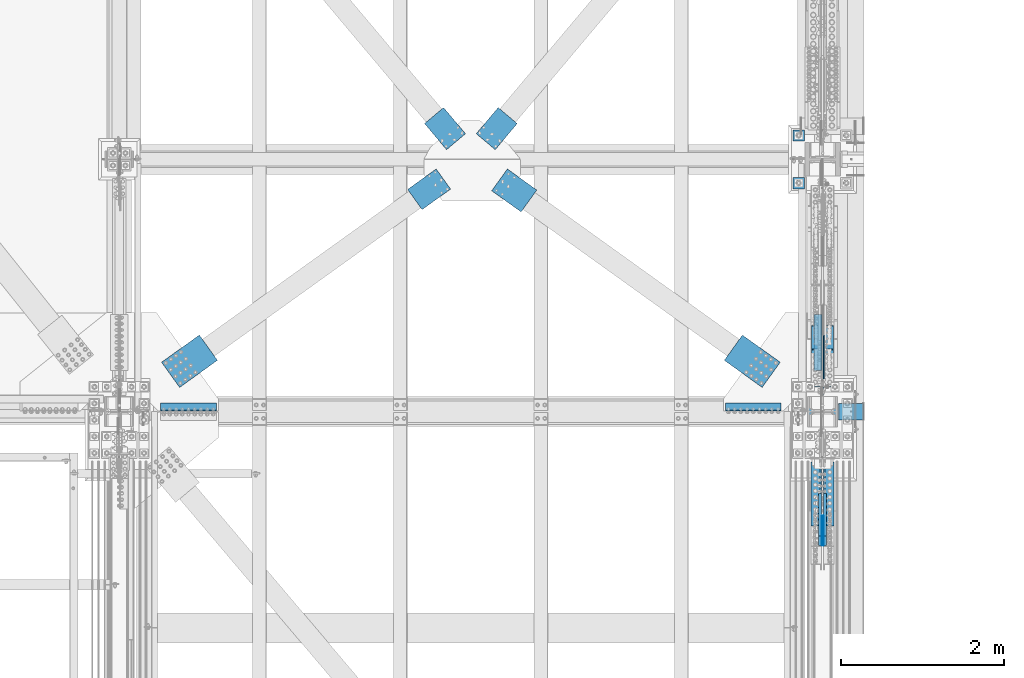
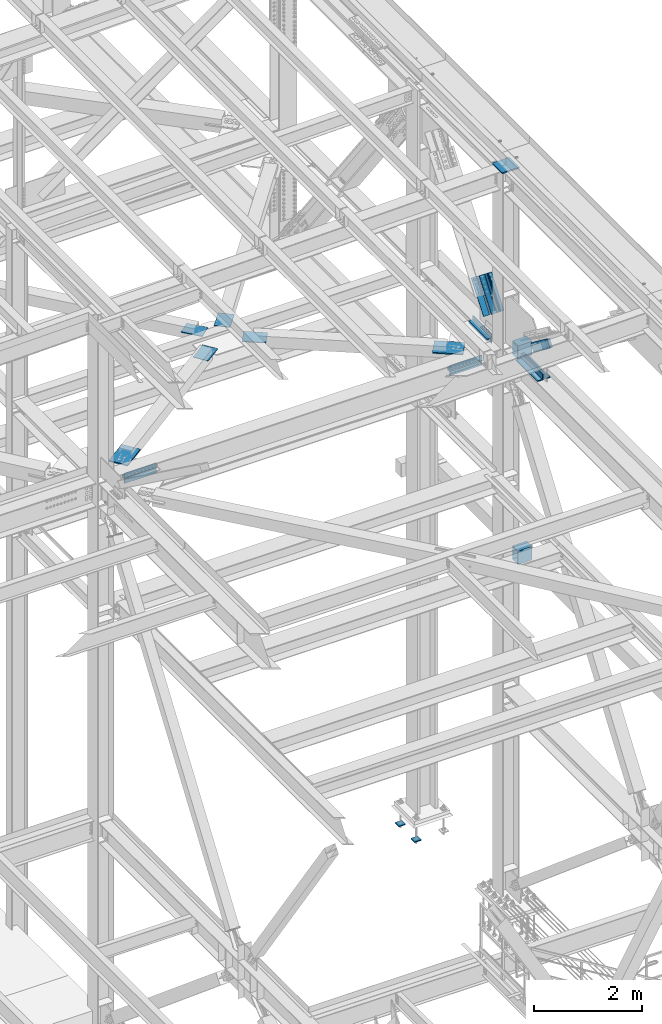
# One storey, part 2591 of 3843: 19 beams, 9 members, 12 elements without a shape of their own.
"""IFC2X3 building model written with IfcOpenShell, lengths in millimetres."""

from ifc_helpers import new_model, si_unit, frame, origin_with_axes, place, context, subcontext, project, spatial, faceted_brep, material, type_object, element, aggregate, save


model = new_model("IFC2X3")

# Units and contexts
model_context = context("Model", 3, precision=1e-05, world=origin_with_axes())
body_context = subcontext(model_context, "Body", "Model", "MODEL_VIEW")
ifc_project = project(units=[si_unit("LENGTHUNIT", "METRE", prefix="MILLI"), si_unit("AREAUNIT", "SQUARE_METRE"), si_unit("VOLUMEUNIT", "CUBIC_METRE"), si_unit("MASSUNIT", "GRAM", prefix="KILO"), si_unit("TIMEUNIT", "SECOND"), si_unit("PLANEANGLEUNIT", "RADIAN"), si_unit("SOLIDANGLEUNIT", "STERADIAN"), si_unit("THERMODYNAMICTEMPERATUREUNIT", "DEGREE_CELSIUS"), si_unit("LUMINOUSINTENSITYUNIT", "LUMEN")], contexts=[model_context])

# Site, building, storey
site_placement = place(None, origin_with_axes())
site = spatial("IfcSite", under=ifc_project, at=site_placement, CompositionType="ELEMENT")
building_placement = place(site_placement, origin_with_axes())
building = spatial("IfcBuilding", under=site, at=building_placement, Name="Undefined", CompositionType="ELEMENT")
storey_placement = place(building_placement, origin_with_axes())
storey = spatial("IfcBuildingStorey", under=building, at=storey_placement, Name="Undefined", CompositionType="ELEMENT", Elevation=0.0)

# Assembly, beam
assembly_1_placement = place(storey_placement, origin_with_axes())
assembly_1 = element("IfcElementAssembly", 1, at=assembly_1_placement, inside=storey, AssemblyPlace="NOTDEFINED", PredefinedType="RIGID_FRAME")
ifc_material_1 = material(Name="STEEL/A572-50")
beam_type_1 = type_object("IfcBeamType", PredefinedType="NOTDEFINED")
beam_1_placement = place(assembly_1_placement, frame((81148.6816315235, 28931.099481789, 42252.9), z_axis=(0.76510760520398, 0.643902440171669, 0.0), x_axis=(-0.64390244017167, 0.76510760520398, 0.0)))
beam_1 = element("IfcBeam", 2, at=beam_1_placement, type_object=beam_type_1, material=ifc_material_1, Name="PLATE", context=body_context, shape_type="Brep", body=[
    faceted_brep([(-1.0550138540566e-10, 6.34999999999854, -152.400000000664), (1.0550138540566e-10, 6.34999999999854, 152.400000000656), (419.100000001017, 6.34999999999854, 152.400000000365), (419.100000000799, 6.34999999999854, -152.400000000969), (1.0550138540566e-10, -6.34999999999854, 152.400000000656), (419.100000001017, -6.34999999999854, 152.400000000365), (-1.0550138540566e-10, -6.34999999999854, -152.400000000664), (419.100000000799, -6.34999999999854, -152.400000000969)], [[[0, 1, 2, 3]], [[1, 4, 5, 2]], [[4, 6, 7, 5]], [[6, 0, 3, 7]], [[5, 7, 3, 2]], [[6, 4, 1, 0]]]),
])
aggregate(assembly_1, [beam_1])

assembly_2_placement = place(storey_placement, origin_with_axes())
assembly_2 = element("IfcElementAssembly", 3, at=assembly_2_placement, inside=storey, AssemblyPlace="NOTDEFINED", PredefinedType="RIGID_FRAME")
beam_2_placement = place(assembly_2_placement, frame((81512.9183788908, 28931.0994845713, 42252.9), z_axis=(0.76510760520398, -0.643902440171669, 0.0), x_axis=(0.643902440171668, 0.765107605203982, 0.0)))
beam_2 = element("IfcBeam", 4, at=beam_2_placement, type_object=beam_type_1, material=ifc_material_1, Name="PLATE", context=body_context, shape_type="Brep", body=[
    faceted_brep([(-1.0550138540566e-10, 6.34999999999854, -152.400000000664), (1.0550138540566e-10, 6.34999999999854, 152.400000000656), (419.100000001017, 6.34999999999854, 152.400000000365), (419.100000000799, 6.34999999999854, -152.400000000969), (1.0550138540566e-10, -6.34999999999854, 152.400000000656), (419.100000001017, -6.34999999999854, 152.400000000365), (-1.0550138540566e-10, -6.34999999999854, -152.400000000664), (419.100000000799, -6.34999999999854, -152.400000000969)], [[[0, 1, 2, 3]], [[1, 4, 5, 2]], [[4, 6, 7, 5]], [[6, 0, 3, 7]], [[5, 7, 3, 2]], [[6, 4, 1, 0]]]),
])
aggregate(assembly_2, [beam_2])

assembly_3_placement = place(storey_placement, origin_with_axes())
assembly_3 = element("IfcElementAssembly", 5, at=assembly_3_placement, inside=storey, AssemblyPlace="NOTDEFINED", PredefinedType="RIGID_FRAME")
beam_3_placement = place(assembly_3_placement, frame((80993.4690277042, 28472.6154205043, 42252.8994997978), z_axis=(-0.583045050783809, 0.812439824698731, 0.0), x_axis=(-0.812439824698731, -0.583045050783809, 0.0)))
beam_3 = element("IfcBeam", 6, at=beam_3_placement, type_object=beam_type_1, material=ifc_material_1, Name="PLATE", context=body_context, shape_type="Brep", body=[
    faceted_brep([(-1.0550138540566e-10, 6.34999999999854, -152.400000000664), (1.0550138540566e-10, 6.34999999999854, 152.400000000656), (431.799987794657, 6.34999999999854, 152.399999999616), (431.799987795937, 6.34999999999854, -152.399999999285), (1.0550138540566e-10, -6.34999999999854, 152.400000000656), (431.799987794657, -6.34999999999854, 152.399999999616), (-1.0550138540566e-10, -6.34999999999854, -152.400000000664), (431.799987795937, -6.34999999999854, -152.399999999285)], [[[0, 1, 2, 3]], [[1, 4, 5, 2]], [[4, 6, 7, 5]], [[6, 0, 3, 7]], [[5, 7, 3, 2]], [[6, 4, 1, 0]]]),
])

# Assembly, beams
assembly_4_placement = place(storey_placement, origin_with_axes())
assembly_4 = element("IfcElementAssembly", 7, at=assembly_4_placement, inside=storey, Name="PLATE", AssemblyPlace="NOTDEFINED", PredefinedType="RIGID_FRAME")
beam_type_2 = type_object("IfcBeamType", Name="L4X4X1/2", PredefinedType="NOTDEFINED")
beam_4_placement = place(assembly_4_placement, frame((84455.0, 25673.0499999974, 42297.35), z_axis=(0.0, 1.0, 0.0), x_axis=(1.0, 0.0, 0.0)))
beam_4 = element("IfcBeam", 8, at=beam_4_placement, type_object=beam_type_2, material=ifc_material_1, Name="ANGLE", ObjectType="L4X4X1/2", context=body_context, shape_type="Brep", body=[
    faceted_brep([(0.0, 50.8000000000029, -50.8000000000029), (0.0, 50.8000000000029, 50.8000000000029), (685.800000000003, 50.8000000000029, 50.8000000000029), (685.800000000003, 50.8000000000029, -50.8000000000029), (0.0, 38.0999999999985, 50.8000000000029), (685.800000000003, 38.0999999999985, 50.8000000000029), (0.0, 38.0999999999985, -38.0999999999985), (685.800000000003, 38.0999999999985, -38.1000000000058), (0.0, -50.8000000000029, -38.1000000000058), (685.800000000003, -50.8000000000029, -38.1000000000058), (0.0, -50.8000000000029, -50.8000000000029), (685.800000000003, -50.8000000000029, -50.8000000000029)], [[[0, 1, 2, 3]], [[1, 4, 5, 2]], [[4, 6, 7, 5]], [[6, 8, 9, 7]], [[8, 10, 11, 9]], [[10, 0, 3, 11]], [[5, 7, 9, 11, 3, 2]], [[10, 8, 6, 4, 1, 0]]]),
])
beam_5_placement = place(assembly_4_placement, frame((85140.8, 25673.0499999974, 42167.175), z_axis=(0.0, 1.0, 0.0), x_axis=(-1.0, 0.0, 0.0)))
beam_5 = element("IfcBeam", 9, at=beam_5_placement, type_object=beam_type_2, material=ifc_material_1, Name="ANGLE", ObjectType="L4X4X1/2", context=body_context, shape_type="Brep", body=[
    faceted_brep([(0.0, 50.8000000000029, -50.8000000000029), (0.0, 50.8000000000029, 50.8000000000029), (685.800000000003, 50.8000000000029, 50.8000000000029), (685.800000000003, 50.8000000000029, -50.8000000000029), (0.0, 38.0999999999985, 50.8000000000029), (685.800000000003, 38.0999999999985, 50.8000000000029), (0.0, 38.0999999999985, -38.0999999999985), (685.800000000003, 38.0999999999985, -38.1000000000058), (0.0, -50.8000000000029, -38.1000000000058), (685.800000000003, -50.8000000000029, -38.1000000000058), (0.0, -50.8000000000029, -50.8000000000029), (685.800000000003, -50.8000000000029, -50.8000000000029)], [[[0, 1, 2, 3]], [[1, 4, 5, 2]], [[4, 6, 7, 5]], [[6, 8, 9, 7]], [[8, 10, 11, 9]], [[10, 0, 3, 11]], [[5, 7, 9, 11, 3, 2]], [[10, 8, 6, 4, 1, 0]]]),
])
beam_6_placement = place(assembly_4_placement, frame((85591.6500000191, 26123.9, 42297.35), z_axis=(-1.0, 0.0, 0.0), x_axis=(0.0, 1.0, 0.0)))
beam_6 = element("IfcBeam", 10, at=beam_6_placement, type_object=beam_type_2, material=ifc_material_1, Name="ANGLE", ObjectType="L4X4X1/2", context=body_context, shape_type="Brep", body=[
    faceted_brep([(0.0, 50.8000000000029, -50.8000000000029), (0.0, 50.8000000000029, 50.8000000000029), (685.800000000003, 50.8000000000029, 50.8000000000029), (685.800000000003, 50.8000000000029, -50.8000000000029), (0.0, 38.0999999999985, 50.8000000000029), (685.800000000003, 38.0999999999985, 50.8000000000029), (0.0, 38.0999999999985, -38.0999999999985), (685.800000000003, 38.0999999999985, -38.1000000000058), (0.0, -50.8000000000029, -38.1000000000058), (685.800000000003, -50.8000000000029, -38.1000000000058), (0.0, -50.8000000000029, -50.8000000000029), (685.800000000003, -50.8000000000029, -50.8000000000029)], [[[0, 1, 2, 3]], [[1, 4, 5, 2]], [[4, 6, 7, 5]], [[6, 8, 9, 7]], [[8, 10, 11, 9]], [[10, 0, 3, 11]], [[5, 7, 9, 11, 3, 2]], [[10, 8, 6, 4, 1, 0]]]),
])

assembly_5_placement = place(storey_placement, origin_with_axes())
assembly_5 = element("IfcElementAssembly", 11, at=assembly_5_placement, inside=storey, Name="PLATE", AssemblyPlace="NOTDEFINED", PredefinedType="RIGID_FRAME")
beam_7_placement = place(assembly_5_placement, frame((77520.8, 25673.0499999996, 42297.3500007629), z_axis=(0.0, 1.0, 0.0), x_axis=(1.0, 0.0, 0.0)))
beam_7 = element("IfcBeam", 12, at=beam_7_placement, type_object=beam_type_2, material=ifc_material_1, Name="ANGLE", ObjectType="L4X4X1/2", context=body_context, shape_type="Brep", body=[
    faceted_brep([(0.0, 50.8000000000029, -50.8000000000029), (0.0, 50.8000000000029, 50.8000000000029), (685.800000000003, 50.8000000000029, 50.8000000000029), (685.800000000003, 50.8000000000029, -50.8000000000029), (0.0, 38.0999999999985, 50.8000000000029), (685.800000000003, 38.0999999999985, 50.8000000000029), (0.0, 38.0999999999985, -38.0999999999985), (685.800000000003, 38.0999999999985, -38.1000000000058), (0.0, -50.8000000000029, -38.1000000000058), (685.800000000003, -50.8000000000029, -38.1000000000058), (0.0, -50.8000000000029, -50.8000000000029), (685.800000000003, -50.8000000000029, -50.8000000000029)], [[[0, 1, 2, 3]], [[1, 4, 5, 2]], [[4, 6, 7, 5]], [[6, 8, 9, 7]], [[8, 10, 11, 9]], [[10, 0, 3, 11]], [[5, 7, 9, 11, 3, 2]], [[10, 8, 6, 4, 1, 0]]]),
])
beam_8_placement = place(assembly_5_placement, frame((78206.6, 25673.0499999996, 42167.175), z_axis=(0.0, 1.0, 0.0), x_axis=(-1.0, 0.0, 0.0)))
beam_8 = element("IfcBeam", 13, at=beam_8_placement, type_object=beam_type_2, material=ifc_material_1, Name="ANGLE", ObjectType="L4X4X1/2", context=body_context, shape_type="Brep", body=[
    faceted_brep([(0.0, 50.8000000000029, -50.8000000000029), (0.0, 50.8000000000029, 50.8000000000029), (685.800000000003, 50.8000000000029, 50.8000000000029), (685.800000000003, 50.8000000000029, -50.8000000000029), (0.0, 38.0999999999985, 50.8000000000029), (685.800000000003, 38.0999999999985, 50.8000000000029), (0.0, 38.0999999999985, -38.0999999999985), (685.800000000003, 38.0999999999985, -38.1000000000058), (0.0, -50.8000000000029, -38.1000000000058), (685.800000000003, -50.8000000000029, -38.1000000000058), (0.0, -50.8000000000029, -50.8000000000029), (685.800000000003, -50.8000000000029, -50.8000000000029)], [[[0, 1, 2, 3]], [[1, 4, 5, 2]], [[4, 6, 7, 5]], [[6, 8, 9, 7]], [[8, 10, 11, 9]], [[10, 0, 3, 11]], [[5, 7, 9, 11, 3, 2]], [[10, 8, 6, 4, 1, 0]]]),
])
aggregate(assembly_5, [beam_7, beam_8])

assembly_6_placement = place(storey_placement, origin_with_axes())
assembly_6 = element("IfcElementAssembly", 14, at=assembly_6_placement, inside=storey, Name="COLUMN", AssemblyPlace="NOTDEFINED", PredefinedType="RIGID_FRAME")
ifc_material_2 = material()
beam_type_3 = type_object("IfcBeamType", Name="HSS12X8X3/8", PredefinedType="NOTDEFINED")
beam_9_placement = place(assembly_6_placement, frame((85832.95, 25615.9, 37592.0), z_axis=(0.0, 0.0, 1.0), x_axis=(1.0, 0.0, 0.0)))
beam_9 = element("IfcBeam", 15, at=beam_9_placement, type_object=beam_type_3, material=ifc_material_2, Name="BEAM", ObjectType="HSS12X8X3/8", context=body_context, shape_type="Brep", body=[
    faceted_brep([(15.8750001309381, 101.600000000006, 152.399999999972), (15.8749984899478, 101.600000000006, -152.400000000031), (6.35000000002037, 92.0749999999971, -142.875), (6.35000000002037, 92.0749999999971, 142.875), (15.8749984899478, -101.600000000006, -152.400000000031), (6.35000000002037, -92.0749999999971, -142.875), (15.8750001044536, -101.600000052975, 152.399999973481), (6.35000000002037, -92.0749999999971, 142.875), (317.499999999971, -101.599999999999, 152.400000000001), (317.499999999971, 101.599999999999, 152.400000000001), (317.499999999971, -101.599999999999, -152.400000000001), (317.499999999971, 101.599999999999, -152.400000000001), (317.499999999971, -92.0750000000007, 142.875), (317.499999999971, 92.0750000000007, 142.875), (317.499999999971, 92.0750000000007, -142.875), (317.499999999971, -92.0750000000007, -142.875)], [[[0, 1, 2, 3]], [[4, 5, 2, 1]], [[6, 7, 5, 4]], [[8, 9, 0, 6]], [[10, 8, 6, 4]], [[11, 10, 4, 1]], [[9, 11, 1, 0]], [[8, 10, 11, 9], [12, 13, 14, 15]], [[14, 13, 3, 2]], [[15, 14, 2, 5]], [[12, 15, 5, 7]], [[13, 12, 7, 3]], [[0, 3, 7, 6]]]),
])
beam_10_placement = place(assembly_6_placement, frame((85832.95, 25615.9, 42214.8), z_axis=(0.0, 0.0, 1.0), x_axis=(1.0, 0.0, 0.0)))
beam_10 = element("IfcBeam", 16, at=beam_10_placement, type_object=beam_type_3, material=ifc_material_2, Name="BEAM", ObjectType="HSS12X8X3/8", context=body_context, shape_type="Brep", body=[
    faceted_brep([(15.8750001309381, 101.600000000006, 152.399999999972), (15.8749984899478, 101.600000000006, -152.400000000031), (6.35000000002037, 92.0749999999971, -142.875), (6.35000000002037, 92.0749999999971, 142.875), (15.8749984899478, -101.600000000006, -152.400000000031), (6.35000000002037, -92.0749999999971, -142.875), (15.8750001044536, -101.600000052975, 152.399999973481), (6.35000000002037, -92.0749999999971, 142.875), (317.499999999971, -101.599999999999, 152.400000000001), (317.499999999971, 101.599999999999, 152.400000000001), (317.499999999971, -101.599999999999, -152.400000000001), (317.499999999971, 101.599999999999, -152.400000000001), (317.499999999971, -92.0750000000007, 142.875), (317.499999999971, 92.0750000000007, 142.875), (317.499999999971, 92.0750000000007, -142.875), (317.499999999971, -92.0750000000007, -142.875)], [[[0, 1, 2, 3]], [[4, 5, 2, 1]], [[6, 7, 5, 4]], [[8, 9, 0, 6]], [[10, 8, 6, 4]], [[11, 10, 4, 1]], [[9, 11, 1, 0]], [[8, 10, 11, 9], [12, 13, 14, 15]], [[14, 13, 3, 2]], [[15, 14, 2, 5]], [[12, 15, 5, 7]], [[13, 12, 7, 3]], [[0, 3, 7, 6]]]),
])

# Beam
beam_type_4 = type_object("IfcBeamType", Name="L4X3-1/2X1/2", PredefinedType="NOTDEFINED")
beam_11_placement = place(assembly_4_placement, frame((85591.6500000191, 26809.7, 42173.5249992371), z_axis=(-1.0, 0.0, 0.0), x_axis=(0.0, -1.0, 0.0)))
beam_11 = element("IfcBeam", 17, at=beam_11_placement, type_object=beam_type_4, material=ifc_material_1, Name="ANGLE", ObjectType="L4X3-1/2X1/2", context=body_context, shape_type="Brep", body=[
    faceted_brep([(0.0, 44.4499999999971, -50.8000000000029), (0.0, 44.4499999999971, 50.8000000000029), (685.800000000003, 44.4499999999971, 50.8000000000029), (685.800000000003, 44.4499999999971, -50.8000000000029), (0.0, 31.75, 50.8000000000029), (685.800000000003, 31.75, 50.8000000000029), (0.0, 31.7500000838336, -38.0999999999985), (685.800000000003, 31.75, -38.0999999999985), (4.36557456851006e-11, -44.4500000000226, -38.0999999999985), (685.800000000003, -44.4499999999971, -38.0999999999985), (0.0, -44.4499999999971, -50.8000000000029), (685.800000000003, -44.4499999999971, -50.8000000000029)], [[[0, 1, 2, 3]], [[1, 4, 5, 2]], [[4, 6, 7, 5]], [[6, 8, 9, 7]], [[8, 10, 11, 9]], [[10, 0, 3, 11]], [[5, 7, 9, 11, 3, 2]], [[10, 8, 6, 4, 1, 0]]]),
])

aggregate(assembly_4, [beam_11, beam_4, beam_5, beam_6])

# Assembly, beam
assembly_7_placement = place(storey_placement, origin_with_axes())
assembly_7 = element("IfcElementAssembly", 18, at=assembly_7_placement, inside=storey, AssemblyPlace="NOTDEFINED", PredefinedType="RIGID_FRAME")
beam_type_5 = type_object("IfcBeamType", PredefinedType="NOTDEFINED")
beam_12_placement = place(assembly_7_placement, frame((85017.9941944462, 26068.5959297464, 42259.25), z_axis=(0.583045051917548, 0.812439823885107, 0.0), x_axis=(-0.812439823885111, 0.583045051917543, 0.0)))
beam_12 = element("IfcBeam", 19, at=beam_12_placement, type_object=beam_type_5, material=ifc_material_1, Name="PLATE", context=body_context, shape_type="Brep", body=[
    faceted_brep([(5.85714587941766e-10, 12.6999999999971, -190.500000000349), (-6.14818418398499e-10, 12.6999999999971, 190.500000000364), (571.499999996191, 12.6999999999971, 190.49999999936), (571.499999997392, 12.6999999999971, -190.500000001353), (-6.14818418398499e-10, -12.6999999999971, 190.500000000364), (571.499999996191, -12.6999999999971, 190.49999999936), (5.85714587941766e-10, -12.6999999999971, -190.500000000349), (571.499999997392, -12.6999999999971, -190.500000001353)], [[[0, 1, 2, 3]], [[1, 4, 5, 2]], [[4, 6, 7, 5]], [[6, 0, 3, 7]], [[5, 7, 3, 2]], [[6, 4, 1, 0]]]),
])

# Beam
beam_13_placement = place(assembly_3_placement, frame((77643.6058055415, 26068.5959311745, 42259.25), z_axis=(0.583045050783809, -0.812439824698731, 0.0), x_axis=(0.812439824698741, 0.583045050783796, 0.0)))
beam_13 = element("IfcBeam", 20, at=beam_13_placement, type_object=beam_type_5, material=ifc_material_1, Name="PLATE", context=body_context, shape_type="Brep", body=[
    faceted_brep([(5.85714587941766e-10, 12.6999999999971, -190.500000000349), (-6.14818418398499e-10, 12.6999999999971, 190.500000000364), (571.499999996191, 12.6999999999971, 190.49999999936), (571.499999997392, 12.6999999999971, -190.500000001353), (-6.14818418398499e-10, -12.6999999999971, 190.500000000364), (571.499999996191, -12.6999999999971, 190.49999999936), (5.85714587941766e-10, -12.6999999999971, -190.500000000349), (571.499999997392, -12.6999999999971, -190.500000001353)], [[[0, 1, 2, 3]], [[1, 4, 5, 2]], [[4, 6, 7, 5]], [[6, 0, 3, 7]], [[5, 7, 3, 2]], [[6, 4, 1, 0]]]),
])

aggregate(assembly_3, [beam_3, beam_13])

# Assembly, members
assembly_8_placement = place(storey_placement, origin_with_axes())
assembly_8 = element("IfcElementAssembly", 21, at=assembly_8_placement, inside=storey, AssemblyPlace="NOTDEFINED", PredefinedType="RIGID_FRAME")
member_type_1 = type_object("IfcMemberType", PredefinedType="NOTDEFINED")
member_1_placement = place(assembly_8_placement, frame((85680.5500000095, 24557.2005559392, 42998.365203393), z_axis=(0.0, -0.603370707059049, -0.797460839078047), x_axis=(0.0, -0.797460839078042, 0.603370707059057)))
member_1 = element("IfcMember", 22, at=member_1_placement, type_object=member_type_1, material=ifc_material_1, Name="PLATE", context=body_context, shape_type="Brep", body=[
    faceted_brep([(1.16415321826935e-10, 19.0500000000029, -95.2500000001601), (-1.16415321826935e-10, 19.0500000000029, 95.2500000001601), (660.400000008245, 19.0500000000029, 95.2500000025429), (660.400000007954, 19.0500000000029, -95.2499999980901), (-1.16415321826935e-10, -19.0500000000029, 95.2500000001601), (660.400000008245, -19.0500000000029, 95.2500000025429), (1.16415321826935e-10, -19.0500000000029, -95.2500000001601), (660.400000007954, -19.0500000000029, -95.2499999980901)], [[[0, 1, 2, 3]], [[1, 4, 5, 2]], [[4, 6, 7, 5]], [[6, 0, 3, 7]], [[5, 7, 3, 2]], [[6, 4, 1, 0]]]),
])
member_2_placement = place(assembly_8_placement, frame((85617.0500000095, 24557.2005559392, 42998.365203393), z_axis=(0.0, -0.603370707059049, -0.797460839078047), x_axis=(0.0, -0.797460839078042, 0.603370707059057)))
member_2 = element("IfcMember", 23, at=member_2_placement, type_object=member_type_1, material=ifc_material_1, Name="PLATE", context=body_context, shape_type="Brep", body=[
    faceted_brep([(1.16415321826935e-10, 19.0500000000029, -95.2500000001601), (-1.16415321826935e-10, 19.0500000000029, 95.2500000001601), (660.400000008245, 19.0500000000029, 95.2500000025429), (660.400000007954, 19.0500000000029, -95.2499999980901), (-1.16415321826935e-10, -19.0500000000029, 95.2500000001601), (660.400000008245, -19.0500000000029, 95.2500000025429), (1.16415321826935e-10, -19.0500000000029, -95.2500000001601), (660.400000007954, -19.0500000000029, -95.2499999980901)], [[[0, 1, 2, 3]], [[1, 4, 5, 2]], [[4, 6, 7, 5]], [[6, 0, 3, 7]], [[5, 7, 3, 2]], [[6, 4, 1, 0]]]),
])

# Beam
beam_type_6 = type_object("IfcBeamType", PredefinedType="NOTDEFINED")
beam_14_placement = place(assembly_7_placement, frame((81682.5085033657, 28462.2974332145, 42252.8994997978), z_axis=(-0.583045051917552, -0.812439823885104, 0.0), x_axis=(0.81243982388511, -0.583045051917543, 0.0)))
beam_14 = element("IfcBeam", 24, at=beam_14_placement, type_object=beam_type_6, material=ifc_material_1, Name="PLATE", context=body_context, shape_type="Brep", body=[
    faceted_brep([(-4.07453626394272e-10, 6.34999999999854, -165.099999999366), (3.92901711165905e-10, 6.34999999999854, 165.099999999351), (444.499993895726, 6.34999999999854, 165.099999998667), (444.499993894933, 6.34999999999854, -165.100000000035), (3.92901711165905e-10, -6.34999999999854, 165.099999999351), (444.499993895726, -6.34999999999854, 165.099999998667), (-4.07453626394272e-10, -6.34999999999854, -165.099999999366), (444.499993894933, -6.34999999999854, -165.100000000035)], [[[0, 1, 2, 3]], [[1, 4, 5, 2]], [[4, 6, 7, 5]], [[6, 0, 3, 7]], [[5, 7, 3, 2]], [[6, 4, 1, 0]]]),
])

aggregate(assembly_7, [beam_14, beam_12])

# Assembly, members
assembly_9_placement = place(storey_placement, origin_with_axes())
assembly_9 = element("IfcElementAssembly", 25, at=assembly_9_placement, inside=storey, AssemblyPlace="NOTDEFINED", PredefinedType="RIGID_FRAME")
member_type_2 = type_object("IfcMemberType", Name="L5X5X1/2", PredefinedType="NOTDEFINED")
member_3_placement = place(assembly_9_placement, frame((85718.6500000203, 25876.9321269279, 42981.2824779085), z_axis=(0.0, -0.79243809328207, 0.609952349217115), x_axis=(0.0, 0.60995234921711, 0.792438093282074)))
member_3 = element("IfcMember", 26, at=member_3_placement, type_object=member_type_2, material=ifc_material_1, Name="ANGLE", ObjectType="L5X5X1/2", context=body_context, shape_type="Brep", body=[
    faceted_brep([(-1.01863406598568e-10, 63.5, -63.5000000002037), (1.01863406598568e-10, 63.5, 63.5000000002074), (749.300000016152, 63.5, 63.4999999992142), (749.300000016028, 63.5, -63.5000000006548), (1.01863406598568e-10, 50.8000000000029, 63.5000000002074), (749.300000016152, 50.8000000000029, 63.4999999992142), (0.0, 50.8000000000029, -50.8000000000029), (749.30000001605, 50.8000000000029, -50.8000000006577), (-7.27595761418343e-11, -63.5, -50.8000000001666), (749.30000001605, -63.5, -50.8000000006577), (-1.01863406598568e-10, -63.5, -63.5000000002037), (749.300000016028, -63.5, -63.5000000006548)], [[[0, 1, 2, 3]], [[1, 4, 5, 2]], [[4, 6, 7, 5]], [[6, 8, 9, 7]], [[8, 10, 11, 9]], [[10, 0, 3, 11]], [[5, 7, 9, 11, 3, 2]], [[10, 8, 6, 4, 1, 0]]]),
])
member_4_placement = place(assembly_9_placement, frame((85718.6500000203, 26716.4000460085, 43280.6933374707), z_axis=(0.0, 0.792438093282071, -0.609952349217114), x_axis=(0.0, -0.609952349217112, -0.792438093282072)))
member_4 = element("IfcMember", 27, at=member_4_placement, type_object=member_type_2, material=ifc_material_1, Name="ANGLE", ObjectType="L5X5X1/2", context=body_context, shape_type="Brep", body=[
    faceted_brep([(-1.01863406598568e-10, 63.5, -63.5000000002037), (1.01863406598568e-10, 63.5, 63.5000000002074), (749.300000016152, 63.5, 63.4999999992142), (749.300000016028, 63.5, -63.5000000006548), (1.01863406598568e-10, 50.8000000000029, 63.5000000002074), (749.300000016152, 50.8000000000029, 63.4999999992142), (0.0, 50.8000000000029, -50.8000000000029), (749.30000001605, 50.8000000000029, -50.8000000006577), (-7.27595761418343e-11, -63.5, -50.8000000001666), (749.30000001605, -63.5, -50.8000000006577), (-1.01863406598568e-10, -63.5, -63.5000000002037), (749.300000016028, -63.5, -63.5000000006548)], [[[0, 1, 2, 3]], [[1, 4, 5, 2]], [[4, 6, 7, 5]], [[6, 8, 9, 7]], [[8, 10, 11, 9]], [[10, 0, 3, 11]], [[5, 7, 9, 11, 3, 2]], [[10, 8, 6, 4, 1, 0]]]),
])
member_5_placement = place(assembly_9_placement, frame((85578.9500000203, 26333.9694221924, 43575.0563412009), z_axis=(0.0, -0.79243809328207, 0.609952349217115), x_axis=(0.0, -0.609952349217112, -0.792438093282072)))
member_5 = element("IfcMember", 28, at=member_5_placement, type_object=member_type_2, material=ifc_material_1, Name="ANGLE", ObjectType="L5X5X1/2", context=body_context, shape_type="Brep", body=[
    faceted_brep([(-1.01863406598568e-10, 63.5, -63.5000000002037), (1.01863406598568e-10, 63.5, 63.5000000002074), (749.300000016152, 63.5, 63.4999999992142), (749.300000016028, 63.5, -63.5000000006548), (1.01863406598568e-10, 50.8000000000029, 63.5000000002074), (749.300000016152, 50.8000000000029, 63.4999999992142), (0.0, 50.8000000000029, -50.8000000000029), (749.30000001605, 50.8000000000029, -50.8000000006577), (-7.27595761418343e-11, -63.5, -50.8000000001666), (749.30000001605, -63.5, -50.8000000006577), (-1.01863406598568e-10, -63.5, -63.5000000002037), (749.300000016028, -63.5, -63.5000000006548)], [[[0, 1, 2, 3]], [[1, 4, 5, 2]], [[4, 6, 7, 5]], [[6, 8, 9, 7]], [[8, 10, 11, 9]], [[10, 0, 3, 11]], [[5, 7, 9, 11, 3, 2]], [[10, 8, 6, 4, 1, 0]]]),
])
member_6_placement = place(assembly_9_placement, frame((85578.9500000203, 26259.362750744, 42686.9194741783), z_axis=(0.0, 0.792438093282071, -0.609952349217114), x_axis=(0.0, 0.60995234921711, 0.792438093282074)))
member_6 = element("IfcMember", 29, at=member_6_placement, type_object=member_type_2, material=ifc_material_1, Name="ANGLE", ObjectType="L5X5X1/2", context=body_context, shape_type="Brep", body=[
    faceted_brep([(-1.01863406598568e-10, 63.5, -63.5000000002037), (1.01863406598568e-10, 63.5, 63.5000000002074), (749.300000016152, 63.5, 63.4999999992142), (749.300000016028, 63.5, -63.5000000006548), (1.01863406598568e-10, 50.8000000000029, 63.5000000002074), (749.300000016152, 50.8000000000029, 63.4999999992142), (0.0, 50.8000000000029, -50.8000000000029), (749.30000001605, 50.8000000000029, -50.8000000006577), (-7.27595761418343e-11, -63.5, -50.8000000001666), (749.30000001605, -63.5, -50.8000000006577), (-1.01863406598568e-10, -63.5, -63.5000000002037), (749.300000016028, -63.5, -63.5000000006548)], [[[0, 1, 2, 3]], [[1, 4, 5, 2]], [[4, 6, 7, 5]], [[6, 8, 9, 7]], [[8, 10, 11, 9]], [[10, 0, 3, 11]], [[5, 7, 9, 11, 3, 2]], [[10, 8, 6, 4, 1, 0]]]),
])

# Member
member_type_3 = type_object("IfcMemberType", PredefinedType="NOTDEFINED")
member_7_placement = place(assembly_8_placement, frame((85657.5312500095, 24288.815110543, 43201.4296148571), z_axis=(0.0, -0.603370707059049, -0.797460839078047), x_axis=(0.0, -0.797460839078042, 0.603370707059057)))
member_7 = element("IfcMember", 30, at=member_7_placement, type_object=member_type_3, material=ifc_material_1, Name="PLATE", context=body_context, shape_type="Brep", body=[
    faceted_brep([(0.0, 3.17499999999927, -95.25), (-2.44140610448085e-05, 3.17500000000291, 95.2499999999927), (323.850000004109, 3.17500000000291, 95.2500000014152), (323.850000003833, 3.17500000000291, -95.2499999992106), (0.0, -3.17499999999927, 95.25), (323.850000004109, -3.17500000000291, 95.2500000014152), (0.0, -3.17499999999927, -95.25), (323.850000003833, -3.17500000000291, -95.2499999992106)], [[[0, 1, 2, 3]], [[1, 4, 5, 2]], [[4, 6, 7, 5]], [[6, 0, 3, 7]], [[5, 7, 3, 2]], [[6, 4, 1, 0]]]),
])

member_8_placement = place(assembly_8_placement, frame((85640.0687500095, 24288.815110543, 43201.4296148571), z_axis=(0.0, -0.603370707059049, -0.797460839078047), x_axis=(0.0, -0.797460839078042, 0.603370707059057)))
member_8 = element("IfcMember", 31, at=member_8_placement, type_object=member_type_3, material=ifc_material_1, Name="PLATE", context=body_context, shape_type="Brep", body=[
    faceted_brep([(0.0, 3.17499999999927, -95.25), (-2.44140610448085e-05, 3.17500000000291, 95.2499999999927), (323.850000004109, 3.17500000000291, 95.2500000014152), (323.850000003833, 3.17500000000291, -95.2499999992106), (0.0, -3.17499999999927, 95.25), (323.850000004109, -3.17500000000291, 95.2500000014152), (0.0, -3.17499999999927, -95.25), (323.850000003833, -3.17500000000291, -95.2499999992106)], [[[0, 1, 2, 3]], [[1, 4, 5, 2]], [[4, 6, 7, 5]], [[6, 0, 3, 7]], [[5, 7, 3, 2]], [[6, 4, 1, 0]]]),
])

aggregate(assembly_8, [member_1, member_7, member_8, member_2])

# Assembly, beam
assembly_10_placement = place(storey_placement, origin_with_axes())
assembly_10 = element("IfcElementAssembly", 32, at=assembly_10_placement, inside=storey, Name="ANGLE", AssemblyPlace="NOTDEFINED", PredefinedType="RIGID_FRAME")
beam_type_7 = type_object("IfcBeamType", Name="L5X5X3/4", PredefinedType="NOTDEFINED")
beam_15_placement = place(assembly_10_placement, frame((85725.0000000095, 24211.7562500095, 42532.2999999935), z_axis=(0.0, 0.0, 1.0), x_axis=(0.0, 1.0, 0.0)))
beam_15 = element("IfcBeam", 33, at=beam_15_placement, type_object=beam_type_7, material=ifc_material_1, Name="ANGLE", ObjectType="L5X5X3/4", context=body_context, shape_type="Brep", body=[
    faceted_brep([(-1.01863406598568e-10, 63.5, -63.5000000002037), (1.01863406598568e-10, 63.5, 63.5000000002074), (787.399999999994, 63.5, 63.5), (787.399999999994, 63.5, -63.5), (0.0, 44.4499999999971, 63.5), (787.399999999994, 44.4499999999971, 63.5), (-3.63797880709171e-12, 44.4499999999971, -44.4500000000007), (787.399999999994, 44.4499999999971, -44.4499999999971), (0.0, -63.5, -44.4499999999971), (787.399999999994, -63.5, -44.4499999999971), (-1.01863406598568e-10, -63.5, -63.5000000002037), (787.399999999994, -63.5, -63.5)], [[[0, 1, 2, 3]], [[1, 4, 5, 2]], [[4, 6, 7, 5]], [[6, 8, 9, 7]], [[8, 10, 11, 9]], [[10, 0, 3, 11]], [[5, 7, 9, 11, 3, 2]], [[10, 8, 6, 4, 1, 0]]]),
])
aggregate(assembly_10, [beam_15])

assembly_11_placement = place(storey_placement, origin_with_axes())
assembly_11 = element("IfcElementAssembly", 34, at=assembly_11_placement, inside=storey, Name="ANGLE", AssemblyPlace="NOTDEFINED", PredefinedType="RIGID_FRAME")
beam_16_placement = place(assembly_11_placement, frame((85572.6000000107, 24999.1562500095, 42532.2999999941), z_axis=(0.0, 0.0, 1.0), x_axis=(0.0, -1.0, 0.0)))
beam_16 = element("IfcBeam", 35, at=beam_16_placement, type_object=beam_type_7, material=ifc_material_1, Name="ANGLE", ObjectType="L5X5X3/4", context=body_context, shape_type="Brep", body=[
    faceted_brep([(-1.01863406598568e-10, 63.5, -63.5000000002037), (1.01863406598568e-10, 63.5, 63.5000000002074), (787.399999999994, 63.5, 63.5), (787.399999999994, 63.5, -63.5), (0.0, 44.4499999999971, 63.5), (787.399999999994, 44.4499999999971, 63.5), (-3.63797880709171e-12, 44.4499999999971, -44.4500000000007), (787.399999999994, 44.4499999999971, -44.4499999999971), (0.0, -63.5, -44.4499999999971), (787.399999999994, -63.5, -44.4499999999971), (-1.01863406598568e-10, -63.5, -63.5000000002037), (787.399999999994, -63.5, -63.5)], [[[0, 1, 2, 3]], [[1, 4, 5, 2]], [[4, 6, 7, 5]], [[6, 8, 9, 7]], [[8, 10, 11, 9]], [[10, 0, 3, 11]], [[5, 7, 9, 11, 3, 2]], [[10, 8, 6, 4, 1, 0]]]),
])
aggregate(assembly_11, [beam_16])

# Member
member_type_4 = type_object("IfcMemberType", PredefinedType="NOTDEFINED")
member_9_placement = place(assembly_9_placement, frame((85661.5000000203, 26095.2598207584, 42869.3248492896), z_axis=(0.0, -0.79243809328207, 0.609952349217115), x_axis=(0.0, 0.60995234921711, 0.792438093282074)))
member_9 = element("IfcMember", 36, at=member_9_placement, type_object=member_type_4, material=ifc_material_1, Name="PLATE", context=body_context, shape_type="Brep", body=[
    faceted_brep([(-8.00355337560177e-11, 6.35000000000582, -95.2499999999127), (9.45874489843845e-11, 6.35000000000582, 95.2499999998981), (660.399999994639, 6.35000000000582, 95.249999999287), (660.399999994457, 6.35000000000582, -95.2500000005239), (9.45874489843845e-11, -6.35000000000582, 95.2499999998981), (660.399999994639, -6.35000000000582, 95.249999999287), (-8.00355337560177e-11, -6.35000000000582, -95.2499999999127), (660.399999994457, -6.35000000000582, -95.2500000005239)], [[[0, 1, 2, 3]], [[1, 4, 5, 2]], [[4, 6, 7, 5]], [[6, 0, 3, 7]], [[5, 7, 3, 2]], [[6, 4, 1, 0]]]),
])

aggregate(assembly_9, [member_3, member_4, member_5, member_6, member_9])

# Beam
beam_type_8 = type_object("IfcBeamType", PredefinedType="NOTDEFINED")
beam_17_placement = place(assembly_6_placement, frame((85832.95, 25615.9, 46442.3125), z_axis=(0.0, 1.0, 0.0), x_axis=(-1.0, 0.0, 0.0)))
beam_17 = element("IfcBeam", 37, at=beam_17_placement, type_object=beam_type_8, material=ifc_material_1, Name="PLATE", context=body_context, shape_type="Brep", body=[
    faceted_brep([(0.0, 14.2874999999985, -185.737499999999), (0.0, 14.2874999999985, 185.737499999999), (368.299999999988, 14.2874999999985, 185.737499999999), (368.299999999988, 14.2874999999985, -185.737499999999), (0.0, -14.2874999999985, 185.737499999999), (368.299999999988, -14.2874999999985, 185.737499999999), (0.0, -14.2874999999985, -185.737499999999), (368.299999999988, -14.2874999999985, -185.737499999999)], [[[0, 1, 2, 3]], [[1, 4, 5, 2]], [[4, 6, 7, 5]], [[6, 0, 3, 7]], [[5, 7, 3, 2]], [[6, 4, 1, 0]]]),
])

aggregate(assembly_6, [beam_9, beam_10, beam_17])

# Assembly, beams
assembly_12_placement = place(storey_placement, origin_with_axes())
assembly_12 = element("IfcElementAssembly", 38, at=assembly_12_placement, inside=storey, Name="TEMPLATE", AssemblyPlace="NOTDEFINED", PredefinedType="RIGID_FRAME")
beam_type_9 = type_object("IfcBeamType", PredefinedType="NOTDEFINED")
beam_18_placement = place(assembly_12_placement, frame((85426.55, 28422.6, 29656.0875), z_axis=(0.0, 1.0, 0.0), x_axis=(-1.0, 0.0, 0.0)))
beam_18 = element("IfcBeam", 39, at=beam_18_placement, type_object=beam_type_9, material=ifc_material_1, context=body_context, shape_type="Brep", body=[
    faceted_brep([(0.0, 11.1124999999993, -69.8499999999985), (0.0, 11.1124999999993, 69.8499999999985), (139.699999999997, 11.1124999999993, 69.8499999999985), (139.699999999997, 11.1124999999993, -69.8499999999985), (0.0, -11.1124999999993, 69.8499999999985), (139.699999999997, -11.1124999999993, 69.8499999999985), (0.0, -11.1124999999993, -69.8499999999985), (139.699999999997, -11.1124999999993, -69.8499999999985)], [[[0, 1, 2, 3]], [[1, 4, 5, 2]], [[4, 6, 7, 5]], [[6, 0, 3, 7]], [[5, 7, 3, 2]], [[6, 4, 1, 0]]]),
])
beam_19_placement = place(assembly_12_placement, frame((85426.55, 29006.8, 29656.0875), z_axis=(0.0, 1.0, 0.0), x_axis=(-1.0, 0.0, 0.0)))
beam_19 = element("IfcBeam", 40, at=beam_19_placement, type_object=beam_type_9, material=ifc_material_1, context=body_context, shape_type="Brep", body=[
    faceted_brep([(0.0, 11.1124999999993, -69.8499999999985), (0.0, 11.1124999999993, 69.8499999999985), (139.699999999997, 11.1124999999993, 69.8499999999985), (139.699999999997, 11.1124999999993, -69.8499999999985), (0.0, -11.1124999999993, 69.8499999999985), (139.699999999997, -11.1124999999993, 69.8499999999985), (0.0, -11.1124999999993, -69.8499999999985), (139.699999999997, -11.1124999999993, -69.8499999999985)], [[[0, 1, 2, 3]], [[1, 4, 5, 2]], [[4, 6, 7, 5]], [[6, 0, 3, 7]], [[5, 7, 3, 2]], [[6, 4, 1, 0]]]),
])
aggregate(assembly_12, [beam_18, beam_19])

save(model, "model.ifc")
